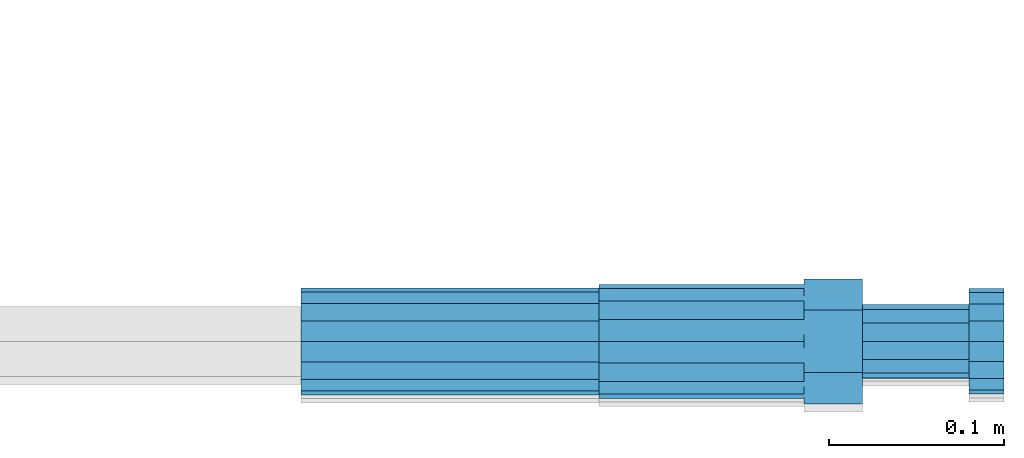
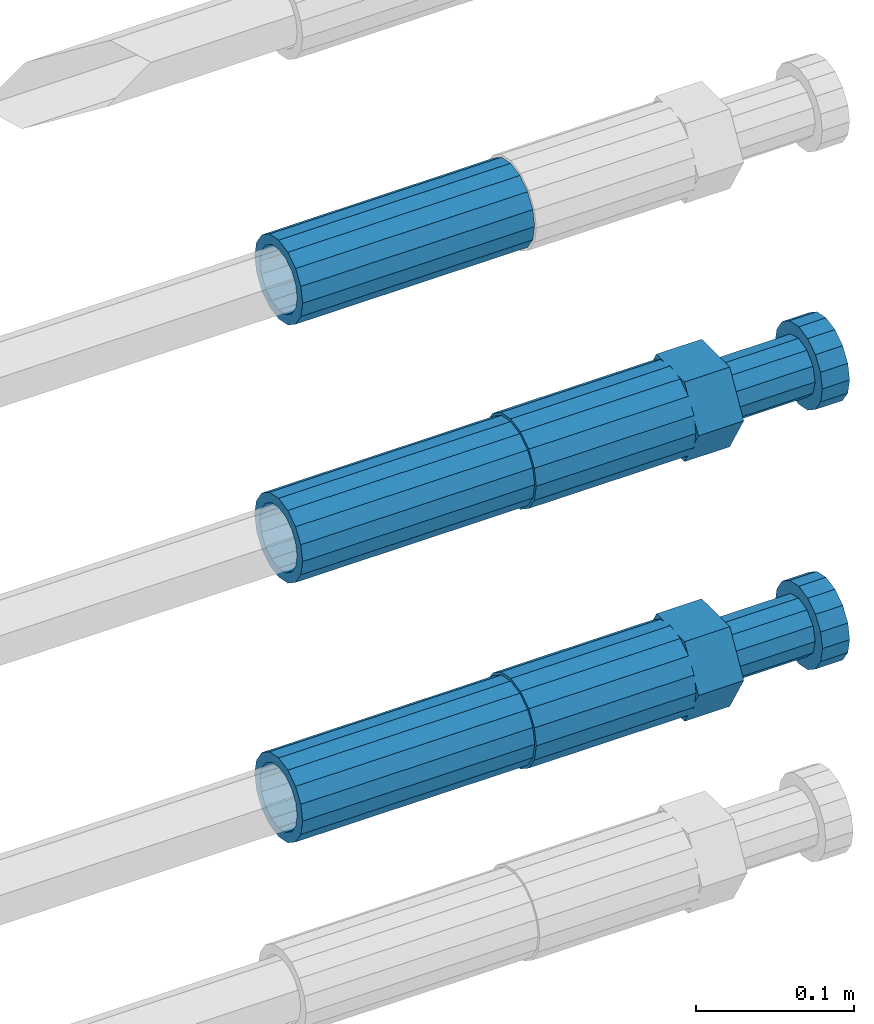
# One storey, part 105 of 119: 5 beams.
"""IFC2X3 building model written with IfcOpenShell, lengths in millimetres."""

import ifcopenshell
import ifcopenshell.guid

model = None  # the IFC model being written
_history = None  # IfcOwnerHistory: only IFC2X3 demands one
_inside = {}  # id of a spatial element -> (the spatial element, [elements in it])
_under = {}  # id of a project, library or spatial element -> (it, [spatial elements below it])
_declared = {}  # id of a project -> (the project, [libraries it declares])
_typed = {}  # id of a type object -> (the type object, [elements of that type])
_made_of = {}  # id of a material, layer set ... -> (it, [elements and type objects made of it])


def new_model(schema):
    """Start an empty IFC model of exactly this schema.

    Asked for "IFC4X3", IfcOpenShell would pick the latest addendum, in which some entities
    have other attributes; the version numbers below select the first issue.
    IFC2X3 requires an IfcOwnerHistory on every rooted entity: one is made here for all.
    """
    global model, _history
    if schema == "IFC4X3":
        model = ifcopenshell.file(schema_version=(4, 3, 0, 0))
    else:
        model = ifcopenshell.file(schema=schema)
    _inside.clear()
    _under.clear()
    _declared.clear()
    _typed.clear()
    _made_of.clear()
    _history = None
    if model.schema == "IFC2X3":
        org = make("IfcOrganization", Name="unknown")
        user = make(
            "IfcPersonAndOrganization",
            ThePerson=make("IfcPerson", FamilyName="unknown"),
            TheOrganization=org,
        )
        app = make(
            "IfcApplication",
            ApplicationDeveloper=org,
            Version="unknown",
            ApplicationFullName="unknown",
            ApplicationIdentifier="unknown",
        )
        _history = make(
            "IfcOwnerHistory",
            OwningUser=user,
            OwningApplication=app,
            ChangeAction="ADDED",
            CreationDate=0,
        )
    return model


def make(cls, **values):
    """One entity of the class cls with the attributes given. An attribute that is None is left unset."""
    return model.create_entity(
        cls, **{name: value for name, value in values.items() if value is not None}
    )


def rooted(cls, **values):
    """An entity with a GlobalId (a new one), such as an element, a storey or a relation."""
    return make(cls, GlobalId=ifcopenshell.guid.new(), OwnerHistory=_history, **values)


def si_unit(unit_type, name, prefix=None):
    """IfcSIUnit, for example si_unit("LENGTHUNIT", "METRE", prefix="MILLI")."""
    return make("IfcSIUnit", UnitType=unit_type, Prefix=prefix, Name=name)


def assignment(units):
    """IfcUnitAssignment: the units of a project."""
    return None if units is None else make("IfcUnitAssignment", Units=units)


def point(xyz):
    """IfcCartesianPoint."""
    return None if xyz is None else make("IfcCartesianPoint", Coordinates=xyz)


def direction(xyz):
    """IfcDirection."""
    return None if xyz is None else make("IfcDirection", DirectionRatios=xyz)


def frame(location, z_axis=None, x_axis=None):
    """IfcAxis2Placement3D, a coordinate frame: its origin and axes. An axis left out is left unset."""
    return make(
        "IfcAxis2Placement3D",
        Location=point(location),
        Axis=direction(z_axis),
        RefDirection=direction(x_axis),
    )


def origin_with_axes():
    """The frame at (0, 0, 0) with the z axis (0, 0, 1) and the x axis (1, 0, 0) written out."""
    return frame((0.0, 0.0, 0.0), z_axis=(0.0, 0.0, 1.0), x_axis=(1.0, 0.0, 0.0))


def place(relative_to, where):
    """IfcLocalPlacement: puts the frame where relative to a parent placement (None: the world)."""
    return make(
        "IfcLocalPlacement", PlacementRelTo=relative_to, RelativePlacement=where
    )


def context(
    kind, dimensions, precision=None, world=None, true_north=None, identifier=None
):
    """IfcGeometricRepresentationContext, for example the 3D "Model" context."""
    return make(
        "IfcGeometricRepresentationContext",
        ContextIdentifier=identifier,
        ContextType=kind,
        CoordinateSpaceDimension=dimensions,
        Precision=precision,
        WorldCoordinateSystem=world,
        TrueNorth=true_north,
    )


def subcontext(parent, identifier, kind, view, scale=None):
    """IfcGeometricRepresentationSubContext, for example "Body" below "Model"."""
    return make(
        "IfcGeometricRepresentationSubContext",
        ContextIdentifier=identifier,
        ContextType=kind,
        ParentContext=parent,
        TargetScale=scale,
        TargetView=view,
    )


def project(units=None, contexts=None):
    """IfcProject with its units and contexts."""
    return rooted(
        "IfcProject",
        Name="project",
        RepresentationContexts=contexts,
        UnitsInContext=assignment(units),
    )


def spatial(cls, under=None, at=None, **own):
    """A site, building, storey or space (cls), placed at a placement, below another one or the project."""
    s = rooted(cls, ObjectPlacement=at, **own)
    if under is not None:
        _under.setdefault(under.id(), (under, []))[1].append(s)
    return s


def faces_of(points, faces, orient=None, outer=None):
    """IfcFace entities. A face is a list of loops; a loop is a list of indices into points, from 0.

    orient and outer hold one flag for each loop. By default every Orientation is true, the
    first loop of a face is its IfcFaceOuterBound and the others are IfcFaceBound.
    """
    made = []
    for i, loops in enumerate(faces):
        bounds = []
        for j, loop in enumerate(loops):
            is_outer = j == 0 if outer is None else outer[i][j]
            bounds.append(
                make(
                    "IfcFaceOuterBound" if is_outer else "IfcFaceBound",
                    Bound=make("IfcPolyLoop", Polygon=[points[k] for k in loop]),
                    Orientation=True if orient is None else orient[i][j],
                )
            )
        made.append(make("IfcFace", Bounds=bounds))
    return made


def faceted_brep(points, faces, orient=None, outer=None, voids=None):
    """IfcFacetedBrep: a solid bounded by flat faces; with voids (closed shells), ...WithVoids."""
    shared = [point(p) for p in points]
    hull = make("IfcClosedShell", CfsFaces=faces_of(shared, faces, orient, outer))
    if voids is None:
        return make("IfcFacetedBrep", Outer=hull)
    return make(
        "IfcFacetedBrepWithVoids",
        Outer=hull,
        Voids=[
            make(cls, CfsFaces=faces_of(shared, fs, o, b)) for cls, fs, o, b in voids
        ],
    )


def shape(context_of_items, identifier, shape_type, items):
    """IfcShapeRepresentation: the items that make up one representation, for example the "Body"."""
    return make(
        "IfcShapeRepresentation",
        ContextOfItems=context_of_items,
        RepresentationIdentifier=identifier,
        RepresentationType=shape_type,
        Items=items,
    )


def material(Name=None, Category=None):
    """IfcMaterial."""
    return make("IfcMaterial", Name=Name, Category=Category)


def made_of(thing, what):
    """Note that an element or type object is made of a material, layer set ...; save() writes the relation."""
    if what is not None:
        _made_of.setdefault(what.id(), (what, []))[1].append(thing)
    return thing


def type_object(cls, material=None, **own):
    """A type object (cls), such as IfcWallType, which elements share."""
    return made_of(rooted(cls, **own), material)


def element(
    cls,
    number,
    at=None,
    inside=None,
    cuts=None,
    type_object=None,
    material=None,
    context=None,
    identifier="Body",
    shape_type=None,
    held_by="IfcProductDefinitionShape",
    body=None,
    shapes=None,
    **own,
):
    """One element of the class cls, such as IfcWall. Its Tag is "e" and its number.

    at: its placement. inside: the storey or other place that contains it. cuts: it is an
    opening in that element (IfcRelVoidsElement). A single representation is given by context,
    identifier, shape_type and body (its items); several are given by shapes. held_by: the class
    of the entity that holds the representations. save() writes the other relations.
    """
    e = rooted(cls, Tag="e%d" % number, ObjectPlacement=at, **own)
    if body is not None:
        shapes = [shape(context, identifier, shape_type, body)]
    if shapes is not None:
        e.Representation = make(held_by, Representations=shapes)
    if inside is not None:
        _inside.setdefault(inside.id(), (inside, []))[1].append(e)
    if cuts is not None:
        rooted(
            "IfcRelVoidsElement", RelatingBuildingElement=cuts, RelatedOpeningElement=e
        )
    if type_object is not None:
        _typed.setdefault(type_object.id(), (type_object, []))[1].append(e)
    return made_of(e, material)


def aggregate(whole, parts):
    """IfcRelAggregates: a whole, such as a stair, and the parts it consists of."""
    return rooted("IfcRelAggregates", RelatingObject=whole, RelatedObjects=parts)


def save(model, path):
    """Write the relations noted so far, then the file.

    IfcRelAggregates (storeys below a building ...), IfcRelContainedInSpatialStructure (elements
    in a storey), IfcRelDefinesByType, IfcRelAssociatesMaterial and IfcRelDeclares: one each for
    every whole, place, type object, material and project.
    """
    for whole, parts in _under.values():
        aggregate(whole, parts)
    for where, things in _inside.values():
        rooted(
            "IfcRelContainedInSpatialStructure",
            RelatedElements=things,
            RelatingStructure=where,
        )
    for kind, things in _typed.values():
        rooted("IfcRelDefinesByType", RelatedObjects=things, RelatingType=kind)
    for what, things in _made_of.values():
        rooted("IfcRelAssociatesMaterial", RelatedObjects=things, RelatingMaterial=what)
    for by, libraries in _declared.values():
        rooted("IfcRelDeclares", RelatingContext=by, RelatedDefinitions=libraries)
    model.write(path)


model = new_model("IFC2X3")

# Units and contexts
model_context = context("Model", 3, precision=1e-05, world=origin_with_axes())
body_context = subcontext(model_context, "Body", "Model", "MODEL_VIEW")
ifc_project = project(units=[si_unit("LENGTHUNIT", "METRE", prefix="MILLI"), si_unit("AREAUNIT", "SQUARE_METRE"), si_unit("VOLUMEUNIT", "CUBIC_METRE"), si_unit("MASSUNIT", "GRAM", prefix="KILO"), si_unit("TIMEUNIT", "SECOND"), si_unit("PLANEANGLEUNIT", "RADIAN"), si_unit("SOLIDANGLEUNIT", "STERADIAN"), si_unit("THERMODYNAMICTEMPERATUREUNIT", "DEGREE_CELSIUS"), si_unit("LUMINOUSINTENSITYUNIT", "LUMEN")], contexts=[model_context])

# Site, building, storey
site_placement = place(None, origin_with_axes())
site = spatial("IfcSite", under=ifc_project, at=site_placement, CompositionType="ELEMENT")
building_placement = place(site_placement, origin_with_axes())
building = spatial("IfcBuilding", under=site, at=building_placement, Name="Undefined", CompositionType="ELEMENT")
storey_placement = place(building_placement, origin_with_axes())
storey = spatial("IfcBuildingStorey", under=building, at=storey_placement, Name="Undefined", CompositionType="ELEMENT", Elevation=0.0)

# Beams
ifc_material = material(Name="STEEL/S275")
beam_type_1 = type_object("IfcBeamType", PredefinedType="NOTDEFINED")
beam_1_placement = place(storey_placement, frame((2039349.03023304, 6205102.98994599, 21306.9894122944), z_axis=(0.0, 0.0, 1.0), x_axis=(1.0, 0.0, 0.0)))
element("IfcBeam", 1, at=beam_1_placement, inside=storey, type_object=beam_type_1, material=ifc_material, Name="AG40N", context=body_context, shape_type="Brep", body=[
    faceted_brep([(1.62981450557709e-09, -23.4999999990687, 0.0), (7.45058059692383e-09, -21.7111690142192, 8.99306066057534), (170.000002125278, -21.711168999318, 8.99306066022245), (170.000002127141, -23.4999999844003, -3.66071617463604e-10), (4.65661287307739e-09, -16.6170093587134, 16.6170093578889), (170.000002122484, -16.6170093440451, 16.6170093575288), (1.86264514923096e-09, -8.99306066217832, 21.7111690140277), (170.000002118759, -8.99306064750999, 21.7111690136603), (2.3283064365387e-10, 9.31322574615479e-10, 23.5), (170.000002114102, 1.28056854009628e-08, 23.4999999996485), (-6.51925802230835e-09, 8.99306065868586, 21.7111690140241), (170.00000211224, 8.99306067335419, 21.7111690136639), (-7.45058059692383e-09, 16.6170093561523, 16.6170093578853), (170.000002109446, 16.6170093708206, 16.6170093575324), (-9.31322574615479e-09, 21.711169013055, 8.99306066057534), (170.000002108514, 21.7111690277234, 8.99306066022245), (-1.16415321826935e-09, 23.5000000009313, 0.0), (170.000002108514, 23.5000000144355, -3.66071617463604e-10), (-8.38190317153931e-09, 21.7111690151505, -8.99306066059444), (170.000002110377, 21.7111690300517, -8.9930606609546), (-5.58793544769287e-09, 16.6170093598776, -16.6170093579008), (170.000002113171, 16.6170093745459, -16.6170093582609), (-9.31322574615479e-10, 8.99306066334248, -21.7111690140396), (170.000002115965, 8.99306067801081, -21.7111690143961), (2.3283064365387e-10, 9.31322574615479e-10, -23.5), (170.00000211969, 1.7927959561348e-08, -23.5000000003843), (5.58793544769287e-09, -8.99306065752171, -21.7111690140396), (170.000002123415, -8.99306064285338, -21.7111690143961), (8.38190317153931e-09, -16.6170093549881, -16.6170093579008), (170.000002125278, -16.6170093403198, -16.6170093582646), (9.31322574615479e-09, -21.7111690121237, -8.99306066059444), (170.000002127141, -21.7111689972226, -8.9930606609546), (1.11758708953857e-08, -30.4999999990687, -9.54969436861575e-12), (1.30385160446167e-08, -28.1783257392235, -11.6718446871514), (170.000002129003, -28.1783257243223, -11.6718446875116), (170.000002129935, -30.4999999841675, -3.66071617463604e-10), (1.02445483207703e-08, -21.5667568228673, -21.5667568262129), (170.000002128072, -21.566756808199, -21.5667568265694), (7.45058059692383e-09, -11.6718446831219, -28.1783257416196), (170.000002125278, -11.6718446684536, -28.1783257419834), (3.72529029846191e-09, 3.95812094211578e-09, -30.5000000000277), (170.00000211969, 1.83936208486557e-08, -30.5000000003879), (-9.31322574615479e-10, 11.6718446905725, -28.1783257416232), (170.000002115965, 11.6718447052408, -28.1783257419797), (-6.51925802230835e-09, 21.5667568286881, -21.5667568262093), (170.000002110377, 21.5667568433564, -21.5667568265694), (-9.31322574615479e-09, 28.178325742716, -11.6718446871478), (170.000002108514, 28.1783257573843, -11.6718446875079), (-1.21071934700012e-08, 30.5, -5.91171556152403e-12), (170.000002106652, 30.5000000144355, -3.62433638656512e-10), (-1.21071934700012e-08, 28.1783257401548, 11.6718446871359), (170.00000210572, 28.1783257548232, 11.6718446867794), (-1.02445483207703e-08, 21.5667568240315, 21.5667568261974), (170.000002107583, 21.566756838467, 21.5667568258409), (-7.45058059692383e-09, 11.671844684286, 28.1783257416041), (170.000002110377, 11.6718446989544, 28.178325741244), (-2.79396772384644e-09, -2.56113708019257e-09, 30.5000000000159), (170.000002114102, 1.18743628263474e-08, 30.4999999996558), (1.86264514923096e-09, -11.6718446896411, 28.1783257416114), (170.000002118759, -11.67184467474, 28.178325741244), (7.45058059692383e-09, -21.5667568275239, 21.5667568261974), (170.000002123415, -21.5667568126228, 21.5667568258373), (1.02445483207703e-08, -28.1783257415518, 11.6718446871359), (170.000002127141, -28.1783257271163, 11.6718446867794)], [[[0, 1, 2, 3]], [[1, 4, 5, 2]], [[4, 6, 7, 5]], [[6, 8, 9, 7]], [[8, 10, 11, 9]], [[10, 12, 13, 11]], [[12, 14, 15, 13]], [[14, 16, 17, 15]], [[16, 18, 19, 17]], [[18, 20, 21, 19]], [[20, 22, 23, 21]], [[22, 24, 25, 23]], [[24, 26, 27, 25]], [[26, 28, 29, 27]], [[28, 30, 31, 29]], [[30, 0, 3, 31]], [[32, 33, 34, 35]], [[33, 36, 37, 34]], [[36, 38, 39, 37]], [[38, 40, 41, 39]], [[40, 42, 43, 41]], [[42, 44, 45, 43]], [[44, 46, 47, 45]], [[46, 48, 49, 47]], [[48, 50, 51, 49]], [[50, 52, 53, 51]], [[52, 54, 55, 53]], [[54, 56, 57, 55]], [[56, 58, 59, 57]], [[58, 60, 61, 59]], [[60, 62, 63, 61]], [[62, 32, 35, 63]], [[37, 39, 41, 43, 45, 47, 49, 51, 53, 55, 57, 59, 61, 63, 35, 34], [5, 7, 9, 11, 13, 15, 17, 19, 21, 23, 25, 27, 29, 31, 3, 2]], [[62, 60, 58, 56, 54, 52, 50, 48, 46, 44, 42, 40, 38, 36, 33, 32], [30, 28, 26, 24, 22, 20, 18, 16, 14, 12, 10, 8, 6, 4, 1, 0]]]),
])
beam_2_placement = place(storey_placement, frame((2039349.03023304, 6205103.07994599, 21507.9694122711), z_axis=(0.0, 0.0, 1.0), x_axis=(1.0, 0.0, 0.0)))
element("IfcBeam", 2, at=beam_2_placement, inside=storey, type_object=beam_type_1, material=ifc_material, Name="AG40N", context=body_context, shape_type="Brep", body=[
    faceted_brep([(1.62981450557709e-09, -23.4999999990687, 0.0), (7.45058059692383e-09, -21.7111690142192, 8.99306066057534), (170.000002125278, -21.711168999318, 8.99306066022245), (170.000002127141, -23.4999999844003, -3.66071617463604e-10), (4.65661287307739e-09, -16.6170093587134, 16.6170093578889), (170.000002122484, -16.6170093440451, 16.6170093575288), (1.86264514923096e-09, -8.99306066217832, 21.7111690140277), (170.000002118759, -8.99306064750999, 21.7111690136603), (2.3283064365387e-10, 9.31322574615479e-10, 23.5), (170.000002114102, 1.28056854009628e-08, 23.4999999996485), (-6.51925802230835e-09, 8.99306065868586, 21.7111690140241), (170.00000211224, 8.99306067335419, 21.7111690136639), (-7.45058059692383e-09, 16.6170093561523, 16.6170093578853), (170.000002109446, 16.6170093708206, 16.6170093575324), (-9.31322574615479e-09, 21.711169013055, 8.99306066057534), (170.000002108514, 21.7111690277234, 8.99306066022245), (-1.16415321826935e-09, 23.5000000009313, 0.0), (170.000002108514, 23.5000000144355, -3.66071617463604e-10), (-8.38190317153931e-09, 21.7111690151505, -8.99306066059444), (170.000002110377, 21.7111690300517, -8.9930606609546), (-5.58793544769287e-09, 16.6170093598776, -16.6170093579008), (170.000002113171, 16.6170093745459, -16.6170093582609), (-9.31322574615479e-10, 8.99306066334248, -21.7111690140396), (170.000002115965, 8.99306067801081, -21.7111690143961), (2.3283064365387e-10, 9.31322574615479e-10, -23.5), (170.00000211969, 1.7927959561348e-08, -23.5000000003843), (5.58793544769287e-09, -8.99306065752171, -21.7111690140396), (170.000002123415, -8.99306064285338, -21.7111690143961), (8.38190317153931e-09, -16.6170093549881, -16.6170093579008), (170.000002125278, -16.6170093403198, -16.6170093582646), (9.31322574615479e-09, -21.7111690121237, -8.99306066059444), (170.000002127141, -21.7111689972226, -8.9930606609546), (1.11758708953857e-08, -30.4999999990687, -9.54969436861575e-12), (1.30385160446167e-08, -28.1783257392235, -11.6718446871514), (170.000002129003, -28.1783257243223, -11.6718446875116), (170.000002129935, -30.4999999841675, -3.66071617463604e-10), (1.02445483207703e-08, -21.5667568228673, -21.5667568262129), (170.000002128072, -21.566756808199, -21.5667568265694), (7.45058059692383e-09, -11.6718446831219, -28.1783257416196), (170.000002125278, -11.6718446684536, -28.1783257419834), (3.72529029846191e-09, 3.95812094211578e-09, -30.5000000000277), (170.00000211969, 1.83936208486557e-08, -30.5000000003879), (-9.31322574615479e-10, 11.6718446905725, -28.1783257416232), (170.000002115965, 11.6718447052408, -28.1783257419797), (-6.51925802230835e-09, 21.5667568286881, -21.5667568262093), (170.000002110377, 21.5667568433564, -21.5667568265694), (-9.31322574615479e-09, 28.178325742716, -11.6718446871478), (170.000002108514, 28.1783257573843, -11.6718446875079), (-1.21071934700012e-08, 30.5, -5.91171556152403e-12), (170.000002106652, 30.5000000144355, -3.62433638656512e-10), (-1.21071934700012e-08, 28.1783257401548, 11.6718446871359), (170.00000210572, 28.1783257548232, 11.6718446867794), (-1.02445483207703e-08, 21.5667568240315, 21.5667568261974), (170.000002107583, 21.566756838467, 21.5667568258409), (-7.45058059692383e-09, 11.671844684286, 28.1783257416041), (170.000002110377, 11.6718446989544, 28.178325741244), (-2.79396772384644e-09, -2.56113708019257e-09, 30.5000000000159), (170.000002114102, 1.18743628263474e-08, 30.4999999996558), (1.86264514923096e-09, -11.6718446896411, 28.1783257416114), (170.000002118759, -11.67184467474, 28.178325741244), (7.45058059692383e-09, -21.5667568275239, 21.5667568261974), (170.000002123415, -21.5667568126228, 21.5667568258373), (1.02445483207703e-08, -28.1783257415518, 11.6718446871359), (170.000002127141, -28.1783257271163, 11.6718446867794)], [[[0, 1, 2, 3]], [[1, 4, 5, 2]], [[4, 6, 7, 5]], [[6, 8, 9, 7]], [[8, 10, 11, 9]], [[10, 12, 13, 11]], [[12, 14, 15, 13]], [[14, 16, 17, 15]], [[16, 18, 19, 17]], [[18, 20, 21, 19]], [[20, 22, 23, 21]], [[22, 24, 25, 23]], [[24, 26, 27, 25]], [[26, 28, 29, 27]], [[28, 30, 31, 29]], [[30, 0, 3, 31]], [[32, 33, 34, 35]], [[33, 36, 37, 34]], [[36, 38, 39, 37]], [[38, 40, 41, 39]], [[40, 42, 43, 41]], [[42, 44, 45, 43]], [[44, 46, 47, 45]], [[46, 48, 49, 47]], [[48, 50, 51, 49]], [[50, 52, 53, 51]], [[52, 54, 55, 53]], [[54, 56, 57, 55]], [[56, 58, 59, 57]], [[58, 60, 61, 59]], [[60, 62, 63, 61]], [[62, 32, 35, 63]], [[37, 39, 41, 43, 45, 47, 49, 51, 53, 55, 57, 59, 61, 63, 35, 34], [5, 7, 9, 11, 13, 15, 17, 19, 21, 23, 25, 27, 29, 31, 3, 2]], [[62, 60, 58, 56, 54, 52, 50, 48, 46, 44, 42, 40, 38, 36, 33, 32], [30, 28, 26, 24, 22, 20, 18, 16, 14, 12, 10, 8, 6, 4, 1, 0]]]),
])
beam_3_placement = place(storey_placement, frame((2039349.03023304, 6205102.98994599, 21707.9894122944), z_axis=(0.0, 0.0, 1.0), x_axis=(1.0, 0.0, 0.0)))
element("IfcBeam", 3, at=beam_3_placement, inside=storey, type_object=beam_type_1, material=ifc_material, Name="AG40N", context=body_context, shape_type="Brep", body=[
    faceted_brep([(1.62981450557709e-09, -23.4999999990687, 0.0), (7.45058059692383e-09, -21.7111690142192, 8.99306066057534), (170.000002125278, -21.711168999318, 8.99306066022245), (170.000002127141, -23.4999999844003, -3.66071617463604e-10), (4.65661287307739e-09, -16.6170093587134, 16.6170093578889), (170.000002122484, -16.6170093440451, 16.6170093575288), (1.86264514923096e-09, -8.99306066217832, 21.7111690140277), (170.000002118759, -8.99306064750999, 21.7111690136603), (2.3283064365387e-10, 9.31322574615479e-10, 23.5), (170.000002114102, 1.28056854009628e-08, 23.4999999996485), (-6.51925802230835e-09, 8.99306065868586, 21.7111690140241), (170.00000211224, 8.99306067335419, 21.7111690136639), (-7.45058059692383e-09, 16.6170093561523, 16.6170093578853), (170.000002109446, 16.6170093708206, 16.6170093575324), (-9.31322574615479e-09, 21.711169013055, 8.99306066057534), (170.000002108514, 21.7111690277234, 8.99306066022245), (-1.16415321826935e-09, 23.5000000009313, 0.0), (170.000002108514, 23.5000000144355, -3.66071617463604e-10), (-8.38190317153931e-09, 21.7111690151505, -8.99306066059444), (170.000002110377, 21.7111690300517, -8.9930606609546), (-5.58793544769287e-09, 16.6170093598776, -16.6170093579008), (170.000002113171, 16.6170093745459, -16.6170093582609), (-9.31322574615479e-10, 8.99306066334248, -21.7111690140396), (170.000002115965, 8.99306067801081, -21.7111690143961), (2.3283064365387e-10, 9.31322574615479e-10, -23.5), (170.00000211969, 1.7927959561348e-08, -23.5000000003843), (5.58793544769287e-09, -8.99306065752171, -21.7111690140396), (170.000002123415, -8.99306064285338, -21.7111690143961), (8.38190317153931e-09, -16.6170093549881, -16.6170093579008), (170.000002125278, -16.6170093403198, -16.6170093582646), (9.31322574615479e-09, -21.7111690121237, -8.99306066059444), (170.000002127141, -21.7111689972226, -8.9930606609546), (1.11758708953857e-08, -30.4999999990687, -9.54969436861575e-12), (1.30385160446167e-08, -28.1783257392235, -11.6718446871514), (170.000002129003, -28.1783257243223, -11.6718446875116), (170.000002129935, -30.4999999841675, -3.66071617463604e-10), (1.02445483207703e-08, -21.5667568228673, -21.5667568262129), (170.000002128072, -21.566756808199, -21.5667568265694), (7.45058059692383e-09, -11.6718446831219, -28.1783257416196), (170.000002125278, -11.6718446684536, -28.1783257419834), (3.72529029846191e-09, 3.95812094211578e-09, -30.5000000000277), (170.00000211969, 1.83936208486557e-08, -30.5000000003879), (-9.31322574615479e-10, 11.6718446905725, -28.1783257416232), (170.000002115965, 11.6718447052408, -28.1783257419797), (-6.51925802230835e-09, 21.5667568286881, -21.5667568262093), (170.000002110377, 21.5667568433564, -21.5667568265694), (-9.31322574615479e-09, 28.178325742716, -11.6718446871478), (170.000002108514, 28.1783257573843, -11.6718446875079), (-1.21071934700012e-08, 30.5, -5.91171556152403e-12), (170.000002106652, 30.5000000144355, -3.62433638656512e-10), (-1.21071934700012e-08, 28.1783257401548, 11.6718446871359), (170.00000210572, 28.1783257548232, 11.6718446867794), (-1.02445483207703e-08, 21.5667568240315, 21.5667568261974), (170.000002107583, 21.566756838467, 21.5667568258409), (-7.45058059692383e-09, 11.671844684286, 28.1783257416041), (170.000002110377, 11.6718446989544, 28.178325741244), (-2.79396772384644e-09, -2.56113708019257e-09, 30.5000000000159), (170.000002114102, 1.18743628263474e-08, 30.4999999996558), (1.86264514923096e-09, -11.6718446896411, 28.1783257416114), (170.000002118759, -11.67184467474, 28.178325741244), (7.45058059692383e-09, -21.5667568275239, 21.5667568261974), (170.000002123415, -21.5667568126228, 21.5667568258373), (1.02445483207703e-08, -28.1783257415518, 11.6718446871359), (170.000002127141, -28.1783257271163, 11.6718446867794)], [[[0, 1, 2, 3]], [[1, 4, 5, 2]], [[4, 6, 7, 5]], [[6, 8, 9, 7]], [[8, 10, 11, 9]], [[10, 12, 13, 11]], [[12, 14, 15, 13]], [[14, 16, 17, 15]], [[16, 18, 19, 17]], [[18, 20, 21, 19]], [[20, 22, 23, 21]], [[22, 24, 25, 23]], [[24, 26, 27, 25]], [[26, 28, 29, 27]], [[28, 30, 31, 29]], [[30, 0, 3, 31]], [[32, 33, 34, 35]], [[33, 36, 37, 34]], [[36, 38, 39, 37]], [[38, 40, 41, 39]], [[40, 42, 43, 41]], [[42, 44, 45, 43]], [[44, 46, 47, 45]], [[46, 48, 49, 47]], [[48, 50, 51, 49]], [[50, 52, 53, 51]], [[52, 54, 55, 53]], [[54, 56, 57, 55]], [[56, 58, 59, 57]], [[58, 60, 61, 59]], [[60, 62, 63, 61]], [[62, 32, 35, 63]], [[37, 39, 41, 43, 45, 47, 49, 51, 53, 55, 57, 59, 61, 63, 35, 34], [5, 7, 9, 11, 13, 15, 17, 19, 21, 23, 25, 27, 29, 31, 3, 2]], [[62, 60, 58, 56, 54, 52, 50, 48, 46, 44, 42, 40, 38, 36, 33, 32], [30, 28, 26, 24, 22, 20, 18, 16, 14, 12, 10, 8, 6, 4, 1, 0]]]),
])
beam_type_2 = type_object("IfcBeamType", Name="ROD65", PredefinedType="NOTDEFINED")
beam_4_placement = place(storey_placement, frame((2039519.03023304, 6205102.98994599, 21306.9894143809), z_axis=(0.0, 0.0, 1.0), x_axis=(1.0, 0.0, 0.0)))
element("IfcBeam", 4, at=beam_4_placement, inside=storey, type_object=beam_type_2, material=ifc_material, Name="AGB40", ObjectType="ROD65", context=body_context, shape_type="Brep", body=[
    faceted_brep([(116.999999999069, 17.8249999252148, 30.8738056446964), (116.999999998137, 22.0056957420893, 23.632628078838), (116.999999999069, 12.4372115600854, 30.0260848066173), (116.999999999069, 8.17543111252598, 30.8738056446964), (117.000000000931, -17.8250000746921, 30.8738056446964), (150.200000001118, -17.8250000723638, 30.8738056446964), (150.199999999255, 17.8249999275431, 30.8738056446964), (117.000000000931, -8.17543109622784, 30.8738056446964), (117.000000001863, -22.0056959956419, 23.6326278985034), (117.000000000931, -12.4372115437873, 30.0260848066173), (117.000000001863, -35.6500000746455, -2.18278728425503e-10), (150.200000002049, -35.6500000723172, -2.18278728425503e-10), (117.000000001863, -30.8443149488885, 8.32369080289209), (117.000000001863, -30.8443149488885, -8.32369080355784), (117.000000002794, -32.4999999918509, 0.0), (117.000000000931, -17.8250000746921, -30.873805645133), (150.200000001118, -17.8250000723638, -30.873805645133), (117.000000001863, -22.0056959961075, -23.6326278982269), (117.000000000931, -8.17543109389953, -30.873805645133), (117.000000000931, -12.4372115437873, -30.0260848066173), (116.999999999069, 17.8249999252148, -30.873805645133), (150.199999999255, 17.8249999275431, -30.873805645133), (116.999999999069, 8.17543111019768, -30.873805645133), (116.999999999069, 12.4372115600854, -30.0260848066173), (116.999999998137, 22.005695742555, -23.6326280785652), (116.999999998137, 35.6499999251682, -2.18278728425503e-10), (150.199999998324, 35.6499999277294, -2.18278728425503e-10), (116.999999998137, 30.8443150522653, -8.32369036550881), (116.999999997206, 32.5000000081491, 0.0), (116.999999998137, 30.8443150522653, 8.32369036483942), (1.86264514923096e-09, -22.9809703885112, 22.9809703885621), (1.86264514923096e-09, -30.0260848065373, 12.4372115518672), (117.000000001863, -30.0260847983882, 12.4372115518672), (117.000000001863, -22.9809703803621, 22.9809703885621), (-1.86264514923096e-09, 22.9809703885112, -22.9809703885621), (-1.86264514923096e-09, 30.0260848065373, -12.4372115518672), (116.999999998137, 30.0260848146863, -12.4372115518672), (116.999999998137, 22.9809703966603, -22.9809703885621), (1.86264514923096e-09, -30.0260848065373, -12.4372115518672), (1.86264514923096e-09, -22.9809703885112, -22.9809703885621), (117.000000001863, -22.9809703803621, -22.9809703885621), (117.000000001863, -30.0260847983882, -12.4372115518672), (9.31322574615479e-10, -12.4372115519363, 30.0260848066173), (0.0, 0.0, 32.5), (-9.31322574615479e-10, 12.4372115519363, 30.0260848066173), (-1.86264514923096e-09, 22.9809703885112, 22.9809703885621), (-1.86264514923096e-09, 30.0260848065373, 12.4372115518672), (-2.79396772384644e-09, 32.5, 0.0), (-9.31322574615479e-10, 12.4372115519363, -30.0260848066173), (0.0, 0.0, -32.5), (9.31322574615479e-10, -12.4372115519363, -30.0260848066173), (2.79396772384644e-09, -32.5, 0.0), (116.999999998137, 22.9809703966603, 22.9809703885621), (116.999999998137, 30.0260848146863, 12.4372115518672), (117.0, 8.14907252788544e-09, -32.5), (117.0, 8.14907252788544e-09, 32.5), (150.200000000186, -10.5000000959262, 18.1865334791873), (150.199999999255, -9.59262251853943e-08, 20.9999999997126), (150.199999998324, 10.4999999040738, 18.1865334791873), (150.199999997392, 18.1865333835594, 10.4999999997126), (150.199999997392, 20.9999999040738, -2.87400325760245e-10), (150.199999997392, 18.1865333835594, -10.5000000002874), (150.199999998324, 10.4999999040738, -18.1865334797621), (150.199999999255, -9.59262251853943e-08, -21.0000000002874), (150.200000000186, -10.5000000959262, -18.1865334797621), (150.200000000186, -18.1865335754119, -10.5000000002874), (150.200000001118, -21.0000000959262, -2.87400325760245e-10), (150.200000000186, -18.1865335754119, 10.4999999997126), (210.979999999516, 10.4999999082647, 18.1865334791873), (210.979999999516, -9.17352735996246e-08, 20.9999999997126), (210.979999997653, 18.1865333877504, 10.4999999997126), (210.979999997653, 20.9999999082647, -2.87400325760245e-10), (210.979999997653, 18.1865333877504, -10.5000000002874), (210.979999999516, 10.4999999082647, -18.1865334797621), (210.979999999516, -9.17352735996246e-08, -21.0000000002874), (210.979999999516, -10.5000000917353, -18.1865334797621), (210.980000000447, -18.1865335712209, -10.5000000002874), (210.980000001378, -21.0000000917353, -2.87400325760245e-10), (210.980000000447, -18.1865335712209, 10.4999999997126), (210.979999999516, -10.5000000917353, 18.1865334791873), (211.001368402503, -27.7269939335529, -11.4911163272045), (211.003082515672, -21.2238095656503, -21.2238154190527), (231.002518340945, -21.2131946226582, -21.2132004554769), (231.000804228708, -27.7163789905608, -11.4805013636287), (211.001368415542, -11.4911086384673, -27.7269970399575), (231.000804241747, -11.4804936954752, -27.7163820763781), (210.996487061493, -0.0106066407170147, -30.0106107396168), (230.995922887698, 8.30227509140968e-06, -29.999995776041), (210.98918159306, 11.4698940692469, -27.7269970332745), (230.988617419265, 11.4805090120062, -27.7163820696951), (210.980564201251, 21.2025913291145, -21.2238154067054), (230.980000027455, 21.2132062721066, -21.2132004431296), (210.971946807578, 27.7057702087332, -11.4911163110701), (230.971382633783, 27.7163851517253, -11.4805013474943), (210.964641331695, 29.9893806746695, -0.0106149565435771), (230.9640771579, 29.9999956176616, 7.03221303410828e-09), (210.959759964608, 27.7057637346443, 11.4698863966551), (230.959195790812, 27.7163786776364, 11.4805013602345), (210.958045851439, 21.2025793667417, 21.2025854885032), (230.957481677644, 21.2131943097338, 21.2132004520827), (210.959759951569, 11.4698784395587, 27.705767109408), (230.959195776843, 11.4804933823179, 27.7163820729838), (210.964641305618, -0.0106235581915826, 29.9893808090674), (230.964077131823, -8.61519947648048e-06, 29.9999957726432), (210.971946774051, -11.4911242681555, 27.7057671027251), (230.971382599324, -11.4805093251634, 27.7163820663009), (210.98056416586, -21.2238215280231, 21.2025854761559), (230.979999991134, -21.2132065852638, 21.2132004397354), (210.989181559533, -27.7270004076418, 11.4698863805206), (230.988617384806, -27.7163854646496, 11.4805013441), (210.996487035416, -30.0106108735781, -0.0106149740058754), (230.995922861621, -29.999995930586, -1.04300852399319e-08)], [[[0, 1, 2, 3]], [[4, 5, 6, 0, 3, 7]], [[8, 4, 7, 9]], [[10, 11, 5, 4, 8, 12]], [[13, 10, 12, 14]], [[15, 16, 11, 10, 13, 17]], [[18, 15, 17, 19]], [[20, 21, 16, 15, 18, 22]], [[20, 22, 23, 24]], [[25, 26, 21, 20, 24, 27]], [[25, 27, 28, 29]], [[30, 31, 32, 33]], [[34, 35, 36, 37]], [[38, 39, 40, 41]], [[31, 30, 42, 43, 44, 45, 46, 47, 35, 34, 48, 49, 50, 39, 38, 51]], [[46, 45, 52, 53]], [[28, 47, 46, 53, 29]], [[27, 36, 35, 47, 28]], [[24, 37, 36, 27]], [[23, 48, 34, 37, 24]], [[22, 54, 49, 48, 23]], [[18, 54, 22]], [[19, 50, 49, 54, 18]], [[17, 40, 39, 50, 19]], [[13, 41, 40, 17]], [[14, 51, 38, 41, 13]], [[12, 32, 31, 51, 14]], [[8, 33, 32, 12]], [[9, 42, 30, 33, 8]], [[7, 55, 43, 42, 9]], [[3, 55, 7]], [[2, 44, 43, 55, 3]], [[1, 52, 45, 44, 2]], [[29, 53, 52, 1]], [[0, 6, 26, 25, 29, 1]], [[5, 11, 16, 21, 26, 6], [56, 57, 58, 59, 60, 61, 62, 63, 64, 65, 66, 67]], [[68, 58, 57, 69]], [[70, 59, 58, 68]], [[71, 60, 59, 70]], [[72, 61, 60, 71]], [[73, 62, 61, 72]], [[74, 63, 62, 73]], [[75, 64, 63, 74]], [[76, 65, 64, 75]], [[77, 66, 65, 76]], [[78, 67, 66, 77]], [[79, 56, 67, 78]], [[69, 57, 56, 79]], [[80, 81, 82, 83]], [[81, 84, 85, 82]], [[84, 86, 87, 85]], [[86, 88, 89, 87]], [[88, 90, 91, 89]], [[90, 92, 93, 91]], [[92, 94, 95, 93]], [[94, 96, 97, 95]], [[96, 98, 99, 97]], [[98, 100, 101, 99]], [[100, 102, 103, 101]], [[102, 104, 105, 103]], [[104, 106, 107, 105]], [[106, 108, 109, 107]], [[108, 110, 111, 109]], [[82, 85, 87, 89, 91, 93, 95, 97, 99, 101, 103, 105, 107, 109, 111, 83]], [[110, 80, 83, 111]], [[108, 106, 104, 102, 100, 98, 96, 94, 92, 90, 88, 86, 84, 81, 80, 110], [78, 77, 76, 75, 74, 73, 72, 71, 70, 68, 69, 79]]]),
])
beam_5_placement = place(storey_placement, frame((2039519.03023304, 6205103.07994599, 21507.9694143674), z_axis=(0.0, 0.0, 1.0), x_axis=(1.0, 0.0, 0.0)))
element("IfcBeam", 5, at=beam_5_placement, inside=storey, type_object=beam_type_2, material=ifc_material, Name="AGB40", ObjectType="ROD65", context=body_context, shape_type="Brep", body=[
    faceted_brep([(116.999999999069, 17.8249999252148, 30.8738056446964), (116.999999998137, 22.0056957420893, 23.632628078838), (116.999999999069, 12.4372115600854, 30.0260848066173), (116.999999999069, 8.17543111252598, 30.8738056446964), (117.000000000931, -17.8250000746921, 30.8738056446964), (150.200000001118, -17.8250000723638, 30.8738056446964), (150.199999999255, 17.8249999275431, 30.8738056446964), (117.000000000931, -8.17543109622784, 30.8738056446964), (117.000000001863, -22.0056959956419, 23.6326278985034), (117.000000000931, -12.4372115437873, 30.0260848066173), (117.000000001863, -35.6500000746455, -2.18278728425503e-10), (150.200000002049, -35.6500000723172, -2.18278728425503e-10), (117.000000001863, -30.8443149488885, 8.32369080289209), (117.000000001863, -30.8443149488885, -8.32369080355784), (117.000000002794, -32.4999999918509, 0.0), (117.000000000931, -17.8250000746921, -30.873805645133), (150.200000001118, -17.8250000723638, -30.873805645133), (117.000000001863, -22.0056959961075, -23.6326278982269), (117.000000000931, -8.17543109389953, -30.873805645133), (117.000000000931, -12.4372115437873, -30.0260848066173), (116.999999999069, 17.8249999252148, -30.873805645133), (150.199999999255, 17.8249999275431, -30.873805645133), (116.999999999069, 8.17543111019768, -30.873805645133), (116.999999999069, 12.4372115600854, -30.0260848066173), (116.999999998137, 22.005695742555, -23.6326280785652), (116.999999998137, 35.6499999251682, -2.18278728425503e-10), (150.199999998324, 35.6499999277294, -2.18278728425503e-10), (116.999999998137, 30.8443150522653, -8.32369036550881), (116.999999997206, 32.5000000081491, 0.0), (116.999999998137, 30.8443150522653, 8.32369036483942), (1.86264514923096e-09, -22.9809703885112, 22.9809703885621), (1.86264514923096e-09, -30.0260848065373, 12.4372115518672), (117.000000001863, -30.0260847983882, 12.4372115518672), (117.000000001863, -22.9809703803621, 22.9809703885621), (-1.86264514923096e-09, 22.9809703885112, -22.9809703885621), (-1.86264514923096e-09, 30.0260848065373, -12.4372115518672), (116.999999998137, 30.0260848146863, -12.4372115518672), (116.999999998137, 22.9809703966603, -22.9809703885621), (1.86264514923096e-09, -30.0260848065373, -12.4372115518672), (1.86264514923096e-09, -22.9809703885112, -22.9809703885621), (117.000000001863, -22.9809703803621, -22.9809703885621), (117.000000001863, -30.0260847983882, -12.4372115518672), (9.31322574615479e-10, -12.4372115519363, 30.0260848066173), (0.0, 0.0, 32.5), (-9.31322574615479e-10, 12.4372115519363, 30.0260848066173), (-1.86264514923096e-09, 22.9809703885112, 22.9809703885621), (-1.86264514923096e-09, 30.0260848065373, 12.4372115518672), (-2.79396772384644e-09, 32.5, 0.0), (-9.31322574615479e-10, 12.4372115519363, -30.0260848066173), (0.0, 0.0, -32.5), (9.31322574615479e-10, -12.4372115519363, -30.0260848066173), (2.79396772384644e-09, -32.5, 0.0), (116.999999998137, 22.9809703966603, 22.9809703885621), (116.999999998137, 30.0260848146863, 12.4372115518672), (117.0, 8.14907252788544e-09, -32.5), (117.0, 8.14907252788544e-09, 32.5), (150.200000000186, -10.5000000959262, 18.1865334791873), (150.199999999255, -9.59262251853943e-08, 20.9999999997126), (150.199999998324, 10.4999999040738, 18.1865334791873), (150.199999997392, 18.1865333835594, 10.4999999997126), (150.199999997392, 20.9999999040738, -2.87400325760245e-10), (150.199999997392, 18.1865333835594, -10.5000000002874), (150.199999998324, 10.4999999040738, -18.1865334797621), (150.199999999255, -9.59262251853943e-08, -21.0000000002874), (150.200000000186, -10.5000000959262, -18.1865334797621), (150.200000000186, -18.1865335754119, -10.5000000002874), (150.200000001118, -21.0000000959262, -2.87400325760245e-10), (150.200000000186, -18.1865335754119, 10.4999999997126), (210.979999999516, 10.4999999082647, 18.1865334791873), (210.979999999516, -9.17352735996246e-08, 20.9999999997126), (210.979999997653, 18.1865333877504, 10.4999999997126), (210.979999997653, 20.9999999082647, -2.87400325760245e-10), (210.979999997653, 18.1865333877504, -10.5000000002874), (210.979999999516, 10.4999999082647, -18.1865334797621), (210.979999999516, -9.17352735996246e-08, -21.0000000002874), (210.979999999516, -10.5000000917353, -18.1865334797621), (210.980000000447, -18.1865335712209, -10.5000000002874), (210.980000001378, -21.0000000917353, -2.87400325760245e-10), (210.980000000447, -18.1865335712209, 10.4999999997126), (210.979999999516, -10.5000000917353, 18.1865334791873), (211.001368402503, -27.7269939335529, -11.4911163272045), (211.003082515672, -21.2238095656503, -21.2238154190527), (231.002518340945, -21.2131946226582, -21.2132004554769), (231.000804228708, -27.7163789905608, -11.4805013636287), (211.001368415542, -11.4911086384673, -27.7269970399575), (231.000804241747, -11.4804936954752, -27.7163820763781), (210.996487061493, -0.0106066407170147, -30.0106107396168), (230.995922887698, 8.30227509140968e-06, -29.999995776041), (210.98918159306, 11.4698940692469, -27.7269970332745), (230.988617419265, 11.4805090120062, -27.7163820696951), (210.980564201251, 21.2025913291145, -21.2238154067054), (230.980000027455, 21.2132062721066, -21.2132004431296), (210.971946807578, 27.7057702087332, -11.4911163110701), (230.971382633783, 27.7163851517253, -11.4805013474943), (210.964641331695, 29.9893806746695, -0.0106149565435771), (230.9640771579, 29.9999956176616, 7.03221303410828e-09), (210.959759964608, 27.7057637346443, 11.4698863966551), (230.959195790812, 27.7163786776364, 11.4805013602345), (210.958045851439, 21.2025793667417, 21.2025854885032), (230.957481677644, 21.2131943097338, 21.2132004520827), (210.959759951569, 11.4698784395587, 27.705767109408), (230.959195776843, 11.4804933823179, 27.7163820729838), (210.964641305618, -0.0106235581915826, 29.9893808090674), (230.964077131823, -8.61519947648048e-06, 29.9999957726432), (210.971946774051, -11.4911242681555, 27.7057671027251), (230.971382599324, -11.4805093251634, 27.7163820663009), (210.98056416586, -21.2238215280231, 21.2025854761559), (230.979999991134, -21.2132065852638, 21.2132004397354), (210.989181559533, -27.7270004076418, 11.4698863805206), (230.988617384806, -27.7163854646496, 11.4805013441), (210.996487035416, -30.0106108735781, -0.0106149740058754), (230.995922861621, -29.999995930586, -1.04300852399319e-08)], [[[0, 1, 2, 3]], [[4, 5, 6, 0, 3, 7]], [[8, 4, 7, 9]], [[10, 11, 5, 4, 8, 12]], [[13, 10, 12, 14]], [[15, 16, 11, 10, 13, 17]], [[18, 15, 17, 19]], [[20, 21, 16, 15, 18, 22]], [[20, 22, 23, 24]], [[25, 26, 21, 20, 24, 27]], [[25, 27, 28, 29]], [[30, 31, 32, 33]], [[34, 35, 36, 37]], [[38, 39, 40, 41]], [[31, 30, 42, 43, 44, 45, 46, 47, 35, 34, 48, 49, 50, 39, 38, 51]], [[46, 45, 52, 53]], [[28, 47, 46, 53, 29]], [[27, 36, 35, 47, 28]], [[24, 37, 36, 27]], [[23, 48, 34, 37, 24]], [[22, 54, 49, 48, 23]], [[18, 54, 22]], [[19, 50, 49, 54, 18]], [[17, 40, 39, 50, 19]], [[13, 41, 40, 17]], [[14, 51, 38, 41, 13]], [[12, 32, 31, 51, 14]], [[8, 33, 32, 12]], [[9, 42, 30, 33, 8]], [[7, 55, 43, 42, 9]], [[3, 55, 7]], [[2, 44, 43, 55, 3]], [[1, 52, 45, 44, 2]], [[29, 53, 52, 1]], [[0, 6, 26, 25, 29, 1]], [[5, 11, 16, 21, 26, 6], [56, 57, 58, 59, 60, 61, 62, 63, 64, 65, 66, 67]], [[68, 58, 57, 69]], [[70, 59, 58, 68]], [[71, 60, 59, 70]], [[72, 61, 60, 71]], [[73, 62, 61, 72]], [[74, 63, 62, 73]], [[75, 64, 63, 74]], [[76, 65, 64, 75]], [[77, 66, 65, 76]], [[78, 67, 66, 77]], [[79, 56, 67, 78]], [[69, 57, 56, 79]], [[80, 81, 82, 83]], [[81, 84, 85, 82]], [[84, 86, 87, 85]], [[86, 88, 89, 87]], [[88, 90, 91, 89]], [[90, 92, 93, 91]], [[92, 94, 95, 93]], [[94, 96, 97, 95]], [[96, 98, 99, 97]], [[98, 100, 101, 99]], [[100, 102, 103, 101]], [[102, 104, 105, 103]], [[104, 106, 107, 105]], [[106, 108, 109, 107]], [[108, 110, 111, 109]], [[82, 85, 87, 89, 91, 93, 95, 97, 99, 101, 103, 105, 107, 109, 111, 83]], [[110, 80, 83, 111]], [[108, 106, 104, 102, 100, 98, 96, 94, 92, 90, 88, 86, 84, 81, 80, 110], [78, 77, 76, 75, 74, 73, 72, 71, 70, 68, 69, 79]]]),
])

save(model, "model.ifc")
